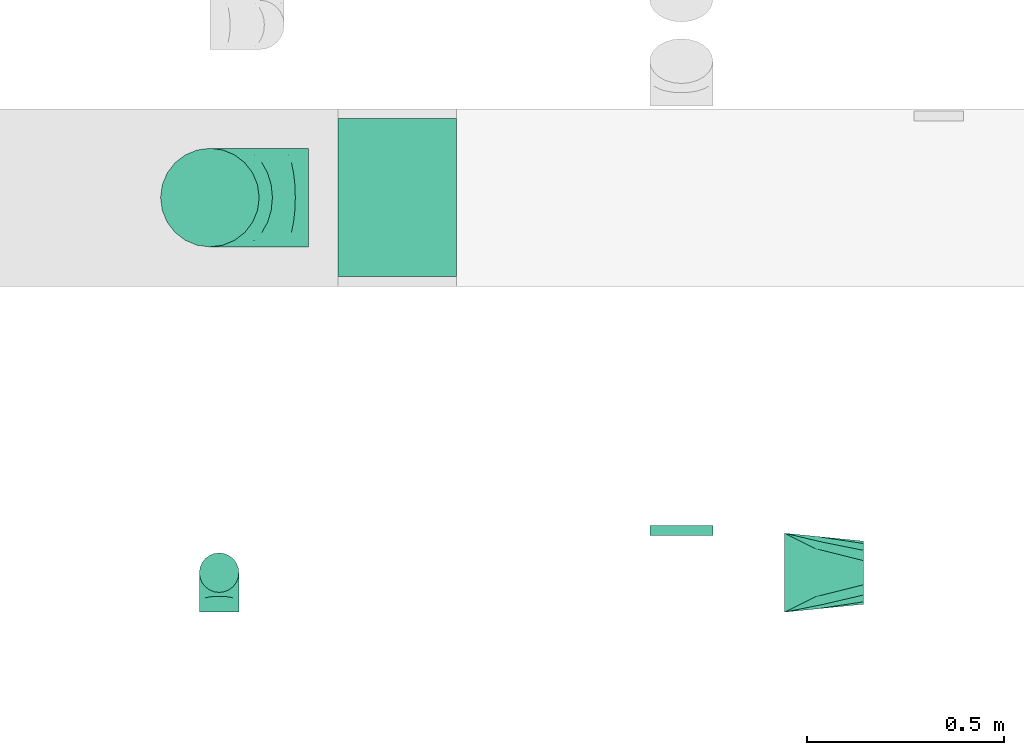
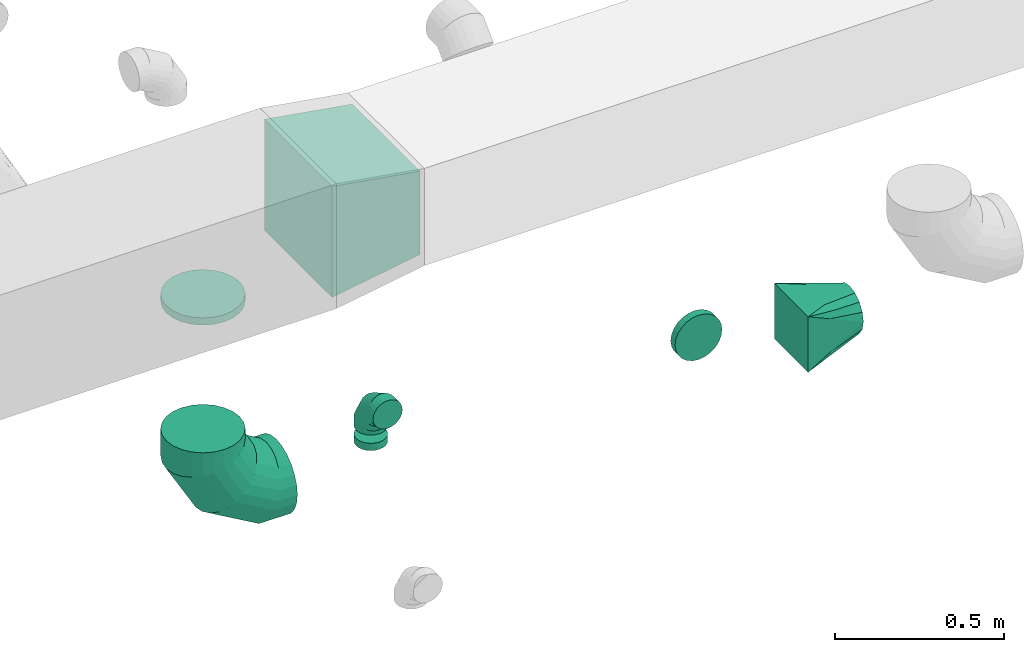
# One storey, part 68 of 97: 7 flow fittings.
"""IFC2X3 building model written with IfcOpenShell, lengths in millimetres."""

from ifc_helpers import new_model, entity, si_unit, converted_unit, derived_unit, direction, frame, origin, place, context, subcontext, project, spatial, polyline, outline, extrude, faceted_brep, source, transform, mapped, material, type_object, type_shapes, element, save


model = new_model("IFC2X3")

# Units and contexts
model_context = context("Model", 3, precision=0.01, world=origin(), true_north=direction((6.12303176911189e-17, 1.0)))
body_context = subcontext(model_context, "Body", "Model", "MODEL_VIEW")
ifc_project = project(units=[si_unit("LENGTHUNIT", "METRE", prefix="MILLI"), si_unit("AREAUNIT", "SQUARE_METRE"), si_unit("VOLUMEUNIT", "CUBIC_METRE"), converted_unit("PLANEANGLEUNIT", "DEGREE", entity("IfcRatioMeasure", 0.0174532925199433), si_unit("PLANEANGLEUNIT", "RADIAN"), dimensions=[0, 0, 0, 0, 0, 0, 0]), si_unit("MASSUNIT", "GRAM", prefix="KILO"), derived_unit("MASSDENSITYUNIT", [(si_unit("MASSUNIT", "GRAM", prefix="KILO"), 1), (si_unit("LENGTHUNIT", "METRE"), -3)]), derived_unit("MOMENTOFINERTIAUNIT", [(si_unit("LENGTHUNIT", "METRE"), 4)]), si_unit("TIMEUNIT", "SECOND"), si_unit("FREQUENCYUNIT", "HERTZ"), si_unit("THERMODYNAMICTEMPERATUREUNIT", "DEGREE_CELSIUS"), derived_unit("THERMALTRANSMITTANCEUNIT", [(si_unit("MASSUNIT", "GRAM", prefix="KILO"), 1), (si_unit("THERMODYNAMICTEMPERATUREUNIT", "KELVIN"), -1), (si_unit("TIMEUNIT", "SECOND"), -3)]), derived_unit("VOLUMETRICFLOWRATEUNIT", [(si_unit("LENGTHUNIT", "METRE"), 3), (si_unit("TIMEUNIT", "SECOND"), -1)]), derived_unit("MASSFLOWRATEUNIT", [(si_unit("MASSUNIT", "GRAM", prefix="KILO"), 1), (si_unit("TIMEUNIT", "SECOND"), -1)]), derived_unit("ROTATIONALFREQUENCYUNIT", [(si_unit("TIMEUNIT", "SECOND"), -1)]), si_unit("ELECTRICCURRENTUNIT", "AMPERE"), si_unit("ELECTRICVOLTAGEUNIT", "VOLT"), si_unit("POWERUNIT", "WATT"), si_unit("FORCEUNIT", "NEWTON", prefix="KILO"), si_unit("ILLUMINANCEUNIT", "LUX"), si_unit("LUMINOUSFLUXUNIT", "LUMEN"), si_unit("LUMINOUSINTENSITYUNIT", "CANDELA"), derived_unit("USERDEFINED", [(si_unit("MASSUNIT", "GRAM", prefix="KILO"), -1), (si_unit("LENGTHUNIT", "METRE"), -2), (si_unit("TIMEUNIT", "SECOND"), 3), (si_unit("LUMINOUSFLUXUNIT", "LUMEN"), 1)]), derived_unit("LINEARVELOCITYUNIT", [(si_unit("LENGTHUNIT", "METRE"), 1), (si_unit("TIMEUNIT", "SECOND"), -1)]), si_unit("PRESSUREUNIT", "PASCAL"), derived_unit("USERDEFINED", [(si_unit("LENGTHUNIT", "METRE"), -2), (si_unit("MASSUNIT", "GRAM", prefix="KILO"), 1), (si_unit("TIMEUNIT", "SECOND"), -2)]), derived_unit("LINEARFORCEUNIT", [(si_unit("MASSUNIT", "GRAM", prefix="KILO"), 1), (si_unit("LENGTHUNIT", "METRE"), 1), (si_unit("TIMEUNIT", "SECOND"), -2), (si_unit("LENGTHUNIT", "METRE"), -1)]), derived_unit("PLANARFORCEUNIT", [(si_unit("MASSUNIT", "GRAM", prefix="KILO"), 1), (si_unit("LENGTHUNIT", "METRE"), 1), (si_unit("TIMEUNIT", "SECOND"), -2), (si_unit("LENGTHUNIT", "METRE"), -2)])], contexts=[model_context])

# Site, building, storey
site_placement = place(None, origin())
site = spatial("IfcSite", under=ifc_project, at=site_placement, CompositionType="ELEMENT")
building_placement = place(site_placement, origin())
building = spatial("IfcBuilding", under=site, at=building_placement, CompositionType="ELEMENT")
storey_placement = place(building_placement, frame((0.0, 0.0, -4900.0)))
storey = spatial("IfcBuildingStorey", under=building, at=storey_placement, CompositionType="ELEMENT", Elevation=-4900.0)

# Flow fittings
ifc_material = material()
duct_fitting_type_1 = type_object("IfcDuctFittingType", PredefinedType="NOTDEFINED", material=ifc_material)
shared_shape_1 = source(origin(), body_context, "Body", "SweptSolid", [
    extrude(outline(polyline([(-180.84, -172.62), (123.3, -172.62), (172.62, 123.3), (-115.08, 221.94), (-180.84, -172.62)])), frame((150.0, -200.0, 0.0), z_axis=(0.0, 1.0, 0.0), x_axis=(0.986393923832128, 0.0, -0.16439898730545)), (0.0, 0.0, 1.0), 400.0),
])
type_shapes(duct_fitting_type_1, [shared_shape_1])
flow_fitting_1_placement = place(storey_placement, frame((55315.5, 15348.96, 4050.0)))
element("IfcFlowFitting", 1, at=flow_fitting_1_placement, inside=storey, type_object=duct_fitting_type_1, material=ifc_material, context=body_context, shape_type="MappedRepresentation", body=[
    mapped(shared_shape_1, transform((0.0, 0.0, 0.0), scale=1.0)),
])
duct_fitting_type_2 = type_object("IfcDuctFittingType", PredefinedType="NOTDEFINED", material=ifc_material)
shared_shape_2 = source(origin(), body_context, "Body", "Brep", [
    faceted_brep([(-100.0, 0.0, -50.0), (-100.0, -12.94, -48.3), (-100.0, -25.0, -43.3), (-100.0, -35.36, -35.36), (-100.0, -43.3, -25.0), (-100.0, -48.3, -12.94), (-100.0, -50.0, 0.0), (-100.0, -48.3, 12.94), (-100.0, -43.3, 25.0), (-100.0, -35.36, 35.36), (-100.0, -25.0, 43.3), (-100.0, -12.94, 48.3), (-100.0, 0.0, 50.0), (-100.0, 12.94, 48.3), (-100.0, 25.0, 43.3), (-100.0, 35.36, 35.36), (-100.0, 43.3, 25.0), (-100.0, 48.3, 12.94), (-100.0, 50.0, 0.0), (-100.0, 48.3, -12.94), (-100.0, 43.3, -25.0), (-100.0, 35.36, -35.36), (-100.0, 25.0, -43.3), (-100.0, 12.94, -48.3), (-76.67, 12.94, 48.3), (-79.9, 25.0, 43.3), (-73.21, 0.0, 50.0), (-82.68, 35.36, 35.36), (-86.15, 48.3, 12.94), (-86.6, 50.0, 0.0), (-84.81, 43.3, 25.0), (-84.81, 43.3, -25.0), (-82.68, 35.36, -35.36), (-86.15, 48.3, -12.94), (-76.67, 12.94, -48.3), (-73.21, 0.0, -50.0), (-79.9, 25.0, -43.3), (-69.74, -12.94, -48.3), (-66.51, -25.0, -43.3), (-63.73, -35.36, -35.36), (-61.6, -43.3, -25.0), (-60.26, -48.3, -12.94), (-59.81, -50.0, 0.0), (-60.26, -48.3, 12.94), (-61.6, -43.3, 25.0), (-63.73, -35.36, 35.36), (-66.51, -25.0, 43.3), (-69.74, -12.94, 48.3), (-36.27, 36.27, 48.3), (-45.1, 45.1, 43.3), (-26.79, 26.79, 50.0), (-52.68, 52.68, 35.36), (-58.49, 58.49, 25.0), (-62.15, 62.15, 12.94), (-63.4, 63.4, 0.0), (-62.15, 62.15, -12.94), (-58.49, 58.49, -25.0), (-52.68, 52.68, -35.36), (-36.27, 36.27, -48.3), (-26.79, 26.79, -50.0), (-45.1, 45.1, -43.3), (-17.32, 17.32, -48.3), (-8.49, 8.49, -43.3), (-0.91, 0.91, -35.36), (4.9, -4.9, -25.0), (8.56, -8.56, -12.94), (9.81, -9.81, 0.0), (8.56, -8.56, 12.94), (4.9, -4.9, 25.0), (-0.91, 0.91, 35.36), (-8.49, 8.49, 43.3), (-17.32, 17.32, 48.3), (-12.94, 76.67, 48.3), (-25.0, 79.9, 43.3), (0.0, 73.21, 50.0), (-35.36, 82.68, 35.36), (-43.3, 84.81, 25.0), (-48.3, 86.15, 12.94), (-50.0, 86.6, 0.0), (-48.3, 86.15, -12.94), (-43.3, 84.81, -25.0), (-35.36, 82.68, -35.36), (-12.94, 76.67, -48.3), (0.0, 73.21, -50.0), (-25.0, 79.9, -43.3), (12.94, 69.74, -48.3), (25.0, 66.51, -43.3), (35.36, 63.73, -35.36), (43.3, 61.6, -25.0), (48.3, 60.26, -12.94), (50.0, 59.81, 0.0), (48.3, 60.26, 12.94), (43.3, 61.6, 25.0), (35.36, 63.73, 35.36), (25.0, 66.51, 43.3), (12.94, 69.74, 48.3), (-12.94, 100.0, -48.3), (-25.0, 100.0, -43.3), (-35.36, 100.0, -35.36), (-43.3, 100.0, -25.0), (-48.3, 100.0, -12.94), (-50.0, 100.0, 0.0), (-48.3, 100.0, 12.94), (-43.3, 100.0, 25.0), (-35.36, 100.0, 35.36), (-25.0, 100.0, 43.3), (-12.94, 100.0, 48.3), (0.0, 100.0, 50.0), (12.94, 100.0, 48.3), (25.0, 100.0, 43.3), (35.36, 100.0, 35.36), (43.3, 100.0, 25.0), (48.3, 100.0, 12.94), (50.0, 100.0, 0.0), (48.3, 100.0, -12.94), (43.3, 100.0, -25.0), (35.36, 100.0, -35.36), (25.0, 100.0, -43.3), (12.94, 100.0, -48.3), (0.0, 100.0, -50.0)], [[[0, 1, 2, 3, 4, 5, 6, 7, 8, 9, 10, 11, 12, 13, 14, 15, 16, 17, 18, 19, 20, 21, 22, 23]], [[24, 25, 14, 13]], [[26, 24, 13, 12]], [[14, 25, 27, 15]], [[28, 29, 18, 17]], [[30, 28, 17, 16]], [[15, 27, 30, 16]], [[20, 31, 32, 21]], [[33, 31, 20, 19]], [[18, 29, 33, 19]], [[34, 35, 0, 23]], [[36, 34, 23, 22]], [[32, 36, 22, 21]], [[2, 1, 37, 38]], [[3, 2, 38, 39]], [[0, 35, 37, 1]], [[5, 4, 40, 41]], [[6, 5, 41, 42]], [[3, 39, 40, 4]], [[6, 42, 43, 7]], [[7, 43, 44, 8]], [[8, 44, 45, 9]], [[10, 46, 47, 11]], [[11, 47, 26, 12]], [[10, 9, 45, 46]], [[48, 49, 25, 24]], [[50, 48, 24, 26]], [[27, 25, 49, 51]], [[52, 53, 28, 30]], [[51, 52, 30, 27]], [[29, 28, 53, 54]], [[55, 56, 31, 33]], [[54, 55, 33, 29]], [[57, 32, 31, 56]], [[58, 59, 35, 34]], [[60, 58, 34, 36]], [[57, 60, 36, 32]], [[37, 35, 59, 61]], [[38, 37, 61, 62]], [[39, 38, 62, 63]], [[41, 40, 64, 65]], [[42, 41, 65, 66]], [[63, 64, 40, 39]], [[43, 42, 66, 67]], [[44, 43, 67, 68]], [[68, 69, 45, 44]], [[46, 45, 69, 70]], [[47, 46, 70, 71]], [[26, 47, 71, 50]], [[72, 73, 49, 48]], [[74, 72, 48, 50]], [[51, 49, 73, 75]], [[76, 77, 53, 52]], [[75, 76, 52, 51]], [[54, 53, 77, 78]], [[79, 80, 56, 55]], [[78, 79, 55, 54]], [[81, 57, 56, 80]], [[82, 83, 59, 58]], [[84, 82, 58, 60]], [[81, 84, 60, 57]], [[61, 59, 83, 85]], [[62, 61, 85, 86]], [[63, 62, 86, 87]], [[65, 64, 88, 89]], [[66, 65, 89, 90]], [[87, 88, 64, 63]], [[67, 66, 90, 91]], [[68, 67, 91, 92]], [[92, 93, 69, 68]], [[70, 69, 93, 94]], [[71, 70, 94, 95]], [[50, 71, 95, 74]], [[96, 97, 98, 99, 100, 101, 102, 103, 104, 105, 106, 107, 108, 109, 110, 111, 112, 113, 114, 115, 116, 117, 118, 119]], [[72, 74, 107, 106]], [[73, 72, 106, 105]], [[75, 73, 105, 104]], [[77, 76, 103, 102]], [[78, 77, 102, 101]], [[75, 104, 103, 76]], [[78, 101, 100, 79]], [[79, 100, 99, 80]], [[80, 99, 98, 81]], [[96, 119, 83, 82]], [[97, 96, 82, 84]], [[84, 81, 98, 97]], [[83, 119, 118, 85]], [[85, 118, 117, 86]], [[86, 117, 116, 87]], [[88, 115, 114, 89]], [[89, 114, 113, 90]], [[87, 116, 115, 88]], [[91, 90, 113, 112]], [[92, 91, 112, 111]], [[93, 92, 111, 110]], [[95, 94, 109, 108]], [[74, 95, 108, 107]], [[110, 109, 94, 93]]]),
])
type_shapes(duct_fitting_type_2, [shared_shape_2])
flow_fitting_2_placement = place(storey_placement, frame((55014.22, 14398.39, 4050.0), z_axis=(1.0, 0.0, 0.0), x_axis=(0.0, 0.0, 1.0)))
element("IfcFlowFitting", 2, at=flow_fitting_2_placement, inside=storey, type_object=duct_fitting_type_2, material=ifc_material, context=body_context, shape_type="MappedRepresentation", body=[
    mapped(shared_shape_2, transform((0.0, 0.0, 0.0), scale=1.0)),
])
duct_fitting_type_3 = type_object("IfcDuctFittingType", PredefinedType="NOTDEFINED", material=ifc_material)
shared_shape_3 = source(origin(), body_context, "Body", "Brep", [
    faceted_brep([(-250.0, 0.0, -125.0), (-250.0, -32.35, -120.74), (-250.0, -62.5, -108.25), (-250.0, -88.39, -88.39), (-250.0, -108.25, -62.5), (-250.0, -120.74, -32.35), (-250.0, -125.0, 0.0), (-250.0, -120.74, 32.35), (-250.0, -108.25, 62.5), (-250.0, -88.39, 88.39), (-250.0, -62.5, 108.25), (-250.0, -32.35, 120.74), (-250.0, 0.0, 125.0), (-250.0, 32.35, 120.74), (-250.0, 62.5, 108.25), (-250.0, 88.39, 88.39), (-250.0, 108.25, 62.5), (-250.0, 120.74, 32.35), (-250.0, 125.0, 0.0), (-250.0, 120.74, -32.35), (-250.0, 108.25, -62.5), (-250.0, 88.39, -88.39), (-250.0, 62.5, -108.25), (-250.0, 32.35, -120.74), (-191.68, 32.35, 120.74), (-199.76, 62.5, 108.25), (-183.01, 0.0, 125.0), (-206.7, 88.39, 88.39), (-215.37, 120.74, 32.35), (-216.51, 125.0, 0.0), (-212.02, 108.25, 62.5), (-212.02, 108.25, -62.5), (-206.7, 88.39, -88.39), (-215.37, 120.74, -32.35), (-191.68, 32.35, -120.74), (-183.01, 0.0, -125.0), (-199.76, 62.5, -108.25), (-174.34, -32.35, -120.74), (-166.27, -62.5, -108.25), (-159.33, -88.39, -88.39), (-154.01, -108.25, -62.5), (-150.66, -120.74, -32.35), (-149.52, -125.0, 0.0), (-150.66, -120.74, 32.35), (-154.01, -108.25, 62.5), (-159.33, -88.39, 88.39), (-166.27, -62.5, 108.25), (-174.34, -32.35, 120.74), (-90.67, 90.67, 120.74), (-112.74, 112.74, 108.25), (-66.99, 66.99, 125.0), (-131.69, 131.69, 88.39), (-146.23, 146.23, 62.5), (-155.38, 155.38, 32.35), (-158.49, 158.49, 0.0), (-155.38, 155.38, -32.35), (-146.23, 146.23, -62.5), (-131.69, 131.69, -88.39), (-90.67, 90.67, -120.74), (-66.99, 66.99, -125.0), (-112.74, 112.74, -108.25), (-43.3, 43.3, -120.74), (-21.23, 21.23, -108.25), (-2.28, 2.28, -88.39), (12.26, -12.26, -62.5), (21.4, -21.4, -32.35), (24.52, -24.52, 0.0), (21.4, -21.4, 32.35), (12.26, -12.26, 62.5), (-2.28, 2.28, 88.39), (-21.23, 21.23, 108.25), (-43.3, 43.3, 120.74), (-32.35, 191.68, 120.74), (-62.5, 199.76, 108.25), (0.0, 183.01, 125.0), (-88.39, 206.7, 88.39), (-108.25, 212.02, 62.5), (-120.74, 215.37, 32.35), (-125.0, 216.51, 0.0), (-120.74, 215.37, -32.35), (-108.25, 212.02, -62.5), (-88.39, 206.7, -88.39), (-32.35, 191.68, -120.74), (0.0, 183.01, -125.0), (-62.5, 199.76, -108.25), (32.35, 174.34, -120.74), (62.5, 166.27, -108.25), (88.39, 159.33, -88.39), (108.25, 154.01, -62.5), (120.74, 150.66, -32.35), (125.0, 149.52, 0.0), (120.74, 150.66, 32.35), (108.25, 154.01, 62.5), (88.39, 159.33, 88.39), (62.5, 166.27, 108.25), (32.35, 174.34, 120.74), (-32.35, 250.0, -120.74), (-62.5, 250.0, -108.25), (-88.39, 250.0, -88.39), (-108.25, 250.0, -62.5), (-120.74, 250.0, -32.35), (-125.0, 250.0, 0.0), (-120.74, 250.0, 32.35), (-108.25, 250.0, 62.5), (-88.39, 250.0, 88.39), (-62.5, 250.0, 108.25), (-32.35, 250.0, 120.74), (0.0, 250.0, 125.0), (32.35, 250.0, 120.74), (62.5, 250.0, 108.25), (88.39, 250.0, 88.39), (108.25, 250.0, 62.5), (120.74, 250.0, 32.35), (125.0, 250.0, 0.0), (120.74, 250.0, -32.35), (108.25, 250.0, -62.5), (88.39, 250.0, -88.39), (62.5, 250.0, -108.25), (32.35, 250.0, -120.74), (0.0, 250.0, -125.0)], [[[0, 1, 2, 3, 4, 5, 6, 7, 8, 9, 10, 11, 12, 13, 14, 15, 16, 17, 18, 19, 20, 21, 22, 23]], [[24, 25, 14, 13]], [[26, 24, 13, 12]], [[14, 25, 27, 15]], [[28, 29, 18, 17]], [[30, 28, 17, 16]], [[15, 27, 30, 16]], [[20, 31, 32, 21]], [[33, 31, 20, 19]], [[18, 29, 33, 19]], [[34, 35, 0, 23]], [[36, 34, 23, 22]], [[21, 32, 36, 22]], [[1, 0, 35, 37]], [[2, 1, 37, 38]], [[38, 39, 3, 2]], [[5, 4, 40, 41]], [[6, 5, 41, 42]], [[39, 40, 4, 3]], [[6, 42, 43, 7]], [[7, 43, 44, 8]], [[8, 44, 45, 9]], [[9, 45, 46, 10]], [[10, 46, 47, 11]], [[26, 12, 11, 47]], [[48, 49, 25, 24]], [[50, 48, 24, 26]], [[27, 25, 49, 51]], [[52, 53, 28, 30]], [[51, 52, 30, 27]], [[29, 28, 53, 54]], [[55, 56, 31, 33]], [[54, 55, 33, 29]], [[32, 31, 56, 57]], [[58, 59, 35, 34]], [[60, 58, 34, 36]], [[57, 60, 36, 32]], [[37, 35, 59, 61]], [[38, 37, 61, 62]], [[39, 38, 62, 63]], [[41, 40, 64, 65]], [[42, 41, 65, 66]], [[63, 64, 40, 39]], [[43, 42, 66, 67]], [[44, 43, 67, 68]], [[68, 69, 45, 44]], [[46, 45, 69, 70]], [[47, 46, 70, 71]], [[26, 47, 71, 50]], [[72, 73, 49, 48]], [[74, 72, 48, 50]], [[51, 49, 73, 75]], [[76, 77, 53, 52]], [[75, 76, 52, 51]], [[54, 53, 77, 78]], [[79, 80, 56, 55]], [[78, 79, 55, 54]], [[57, 56, 80, 81]], [[82, 83, 59, 58]], [[84, 82, 58, 60]], [[81, 84, 60, 57]], [[61, 59, 83, 85]], [[62, 61, 85, 86]], [[63, 62, 86, 87]], [[65, 64, 88, 89]], [[66, 65, 89, 90]], [[87, 88, 64, 63]], [[67, 66, 90, 91]], [[68, 67, 91, 92]], [[92, 93, 69, 68]], [[70, 69, 93, 94]], [[71, 70, 94, 95]], [[50, 71, 95, 74]], [[96, 97, 98, 99, 100, 101, 102, 103, 104, 105, 106, 107, 108, 109, 110, 111, 112, 113, 114, 115, 116, 117, 118, 119]], [[72, 74, 107, 106]], [[73, 72, 106, 105]], [[75, 73, 105, 104]], [[77, 76, 103, 102]], [[78, 77, 102, 101]], [[75, 104, 103, 76]], [[78, 101, 100, 79]], [[79, 100, 99, 80]], [[80, 99, 98, 81]], [[84, 97, 96, 82]], [[82, 96, 119, 83]], [[84, 81, 98, 97]], [[83, 119, 118, 85]], [[85, 118, 117, 86]], [[116, 87, 86, 117]], [[88, 115, 114, 89]], [[89, 114, 113, 90]], [[115, 88, 87, 116]], [[91, 90, 113, 112]], [[92, 91, 112, 111]], [[111, 110, 93, 92]], [[95, 94, 109, 108]], [[74, 95, 108, 107]], [[110, 109, 94, 93]]]),
])
type_shapes(duct_fitting_type_3, [shared_shape_3])
flow_fitting_3_placement = place(storey_placement, frame((54990.79, 15348.96, 3120.0), z_axis=(0.0, 1.0, 0.0), x_axis=(-1.0, 0.0, 0.0)))
element("IfcFlowFitting", 3, at=flow_fitting_3_placement, inside=storey, type_object=duct_fitting_type_3, material=ifc_material, context=body_context, shape_type="MappedRepresentation", body=[
    mapped(shared_shape_3, transform((0.0, 0.0, 0.0), scale=1.0)),
])
duct_fitting_type_4 = type_object("IfcDuctFittingType", PredefinedType="NOTDEFINED", material=ifc_material)
shared_shape_4 = source(origin(), body_context, "Body", "Brep", [
    faceted_brep([(20.0, 0.0, -125.0), (20.0, 32.35, -120.74), (20.0, 62.5, -108.25), (20.0, 88.39, -88.39), (20.0, 108.25, -62.5), (20.0, 120.74, -32.35), (20.0, 125.0, 0.0), (20.0, 120.74, 32.35), (20.0, 108.25, 62.5), (20.0, 88.39, 88.39), (20.0, 62.5, 108.25), (20.0, 32.35, 120.74), (20.0, 0.0, 125.0), (20.0, -32.35, 120.74), (20.0, -62.5, 108.25), (20.0, -88.39, 88.39), (20.0, -108.25, 62.5), (20.0, -120.74, 32.35), (20.0, -125.0, 0.0), (20.0, -120.74, -32.35), (20.0, -108.25, -62.5), (20.0, -88.39, -88.39), (20.0, -62.5, -108.25), (20.0, -32.35, -120.74), (0.0, 0.0, 125.0), (-6.1, 0.0, 125.0), (-6.1, -32.35, 120.74), (0.0, -32.35, 120.74), (-6.1, -62.5, 108.25), (0.0, -62.5, 108.25), (0.0, -88.39, 88.39), (-6.1, -88.39, 88.39), (0.0, -108.25, 62.5), (-6.1, -108.25, 62.5), (-6.1, -120.74, 32.35), (0.0, -120.74, 32.35), (-6.1, -125.0, 0.0), (0.0, -125.0, 0.0), (-6.1, -120.74, -32.35), (0.0, -120.74, -32.35), (-6.1, -108.25, -62.5), (0.0, -108.25, -62.5), (0.0, -88.39, -88.39), (-6.1, -88.39, -88.39), (0.0, -62.5, -108.25), (-6.1, -62.5, -108.25), (-6.1, -32.35, -120.74), (0.0, -32.35, -120.74), (-6.1, 0.0, -125.0), (0.0, 0.0, -125.0), (-6.1, 32.35, -120.74), (0.0, 32.35, -120.74), (-6.1, 62.5, -108.25), (0.0, 62.5, -108.25), (0.0, 88.39, -88.39), (-6.1, 88.39, -88.39), (0.0, 108.25, -62.5), (-6.1, 108.25, -62.5), (-6.1, 120.74, -32.35), (0.0, 120.74, -32.35), (-6.1, 125.0, 0.0), (0.0, 125.0, 0.0), (-6.1, 120.74, 32.35), (0.0, 120.74, 32.35), (-6.1, 108.25, 62.5), (0.0, 108.25, 62.5), (0.0, 88.39, 88.39), (-6.1, 88.39, 88.39), (0.0, 62.5, 108.25), (-6.1, 62.5, 108.25), (-6.1, 32.35, 120.74), (0.0, 32.35, 120.74)], [[[0, 1, 2, 3, 4, 5, 6, 7, 8, 9, 10, 11, 12, 13, 14, 15, 16, 17, 18, 19, 20, 21, 22, 23]], [[13, 12, 24, 25, 26, 27]], [[14, 13, 27, 26, 28, 29]], [[30, 15, 14, 29, 28, 31]], [[17, 16, 32, 33, 34, 35]], [[18, 17, 35, 34, 36, 37]], [[32, 16, 15, 30, 31, 33]], [[19, 18, 37, 36, 38, 39]], [[20, 19, 39, 38, 40, 41]], [[42, 21, 20, 41, 40, 43]], [[23, 22, 44, 45, 46, 47]], [[0, 23, 47, 46, 48, 49]], [[44, 22, 21, 42, 43, 45]], [[1, 0, 49, 48, 50, 51]], [[2, 1, 51, 50, 52, 53]], [[54, 3, 2, 53, 52, 55]], [[5, 4, 56, 57, 58, 59]], [[6, 5, 59, 58, 60, 61]], [[56, 4, 3, 54, 55, 57]], [[7, 6, 61, 60, 62, 63]], [[8, 7, 63, 62, 64, 65]], [[66, 9, 8, 65, 64, 67]], [[11, 10, 68, 69, 70, 71]], [[12, 11, 71, 70, 25, 24]], [[68, 10, 9, 66, 67, 69]], [[46, 45, 43, 40, 38, 36, 34, 33, 31, 28, 26, 25, 70, 69, 67, 64, 62, 60, 58, 57, 55, 52, 50, 48]]]),
])
type_shapes(duct_fitting_type_4, [shared_shape_4])
flow_fitting_4_placement = place(storey_placement, frame((54990.79, 15348.96, 3850.0), z_axis=(0.0, -1.0, 0.0), x_axis=(0.0, 0.0, -1.0)))
element("IfcFlowFitting", 4, at=flow_fitting_4_placement, inside=storey, type_object=duct_fitting_type_4, material=ifc_material, context=body_context, shape_type="MappedRepresentation", body=[
    mapped(shared_shape_4, transform((0.0, 0.0, 0.0), scale=1.0)),
])
duct_fitting_type_5 = type_object("IfcDuctFittingType", PredefinedType="NOTDEFINED", material=ifc_material)
shared_shape_5 = source(origin(), body_context, "Body", "Brep", [
    faceted_brep([(20.0, 20.71, -77.27), (20.0, 40.0, -69.28), (20.0, 56.57, -56.57), (20.0, 69.28, -40.0), (20.0, 77.27, -20.71), (20.0, 80.0, 0.0), (20.0, 77.27, 20.71), (20.0, 69.28, 40.0), (20.0, 56.57, 56.57), (20.0, 40.0, 69.28), (20.0, 20.71, 77.27), (20.0, 0.0, 80.0), (20.0, -20.71, 77.27), (20.0, -40.0, 69.28), (20.0, -56.57, 56.57), (20.0, -69.28, 40.0), (20.0, -77.27, 20.71), (20.0, -80.0, 0.0), (20.0, -77.27, -20.71), (20.0, -69.28, -40.0), (20.0, -56.57, -56.57), (20.0, -40.0, -69.28), (20.0, -20.71, -77.27), (20.0, 0.0, -80.0), (0.0, 0.0, 80.0), (0.0, 20.71, 77.27), (-6.1, 20.71, 77.27), (-6.1, 0.0, 80.0), (0.0, 40.0, 69.28), (-6.1, 40.0, 69.28), (0.0, 56.57, 56.57), (-6.1, 56.57, 56.57), (0.0, 69.28, 40.0), (0.0, 77.27, 20.71), (-6.1, 77.27, 20.71), (-6.1, 69.28, 40.0), (0.0, 80.0, 0.0), (-6.1, 80.0, 0.0), (0.0, 77.27, -20.71), (-6.1, 77.27, -20.71), (0.0, 69.28, -40.0), (-6.1, 69.28, -40.0), (0.0, 56.57, -56.57), (-6.1, 56.57, -56.57), (0.0, 40.0, -69.28), (0.0, 20.71, -77.27), (-6.1, 20.71, -77.27), (-6.1, 40.0, -69.28), (0.0, 0.0, -80.0), (-6.1, 0.0, -80.0), (0.0, -20.71, -77.27), (-6.1, -20.71, -77.27), (0.0, -40.0, -69.28), (-6.1, -40.0, -69.28), (0.0, -56.57, -56.57), (-6.1, -56.57, -56.57), (0.0, -69.28, -40.0), (0.0, -77.27, -20.71), (-6.1, -77.27, -20.71), (-6.1, -69.28, -40.0), (0.0, -80.0, 0.0), (-6.1, -80.0, 0.0), (0.0, -77.27, 20.71), (-6.1, -77.27, 20.71), (0.0, -69.28, 40.0), (-6.1, -69.28, 40.0), (0.0, -56.57, 56.57), (-6.1, -56.57, 56.57), (0.0, -40.0, 69.28), (0.0, -20.71, 77.27), (-6.1, -20.71, 77.27), (-6.1, -40.0, 69.28)], [[[0, 1, 2, 3, 4, 5, 6, 7, 8, 9, 10, 11, 12, 13, 14, 15, 16, 17, 18, 19, 20, 21, 22, 23]], [[24, 11, 10, 25, 26, 27]], [[25, 10, 9, 28, 29, 26]], [[28, 9, 8, 30, 31, 29]], [[32, 7, 6, 33, 34, 35]], [[33, 6, 5, 36, 37, 34]], [[30, 8, 7, 32, 35, 31]], [[36, 5, 4, 38, 39, 37]], [[38, 4, 3, 40, 41, 39]], [[40, 3, 2, 42, 43, 41]], [[44, 1, 0, 45, 46, 47]], [[45, 0, 23, 48, 49, 46]], [[42, 2, 1, 44, 47, 43]], [[48, 23, 22, 50, 51, 49]], [[50, 22, 21, 52, 53, 51]], [[52, 21, 20, 54, 55, 53]], [[56, 19, 18, 57, 58, 59]], [[57, 18, 17, 60, 61, 58]], [[54, 20, 19, 56, 59, 55]], [[60, 17, 16, 62, 63, 61]], [[62, 16, 15, 64, 65, 63]], [[64, 15, 14, 66, 67, 65]], [[68, 13, 12, 69, 70, 71]], [[69, 12, 11, 24, 27, 70]], [[66, 14, 13, 68, 71, 67]], [[49, 51, 53, 55, 59, 58, 61, 63, 65, 67, 71, 70, 27, 26, 29, 31, 35, 34, 37, 39, 41, 43, 47, 46]]]),
])
type_shapes(duct_fitting_type_5, [shared_shape_5])
flow_fitting_5_placement = place(storey_placement, frame((56185.54, 14498.39, 3800.0), z_axis=(0.0, 0.0, -1.0), x_axis=(0.0, 1.0, 0.0)))
element("IfcFlowFitting", 5, at=flow_fitting_5_placement, inside=storey, type_object=duct_fitting_type_5, material=ifc_material, context=body_context, shape_type="MappedRepresentation", body=[
    mapped(shared_shape_5, transform((0.0, 0.0, 0.0), scale=1.0)),
])
duct_fitting_type_6 = type_object("IfcDuctFittingType", PredefinedType="NOTDEFINED", material=ifc_material)
shared_shape_6 = source(origin(), body_context, "Body", "Brep", [
    faceted_brep([(20.0, 12.94, -48.3), (20.0, 25.0, -43.3), (20.0, 35.36, -35.36), (20.0, 43.3, -25.0), (20.0, 48.3, -12.94), (20.0, 50.0, 0.0), (20.0, 48.3, 12.94), (20.0, 43.3, 25.0), (20.0, 35.36, 35.36), (20.0, 25.0, 43.3), (20.0, 12.94, 48.3), (20.0, 0.0, 50.0), (20.0, -12.94, 48.3), (20.0, -25.0, 43.3), (20.0, -35.36, 35.36), (20.0, -43.3, 25.0), (20.0, -48.3, 12.94), (20.0, -50.0, 0.0), (20.0, -48.3, -12.94), (20.0, -43.3, -25.0), (20.0, -35.36, -35.36), (20.0, -25.0, -43.3), (20.0, -12.94, -48.3), (20.0, 0.0, -50.0), (0.0, 0.0, 50.0), (0.0, 12.94, 48.3), (-6.1, 12.94, 48.3), (-6.1, 0.0, 50.0), (0.0, 25.0, 43.3), (-6.1, 25.0, 43.3), (0.0, 35.36, 35.36), (-6.1, 35.36, 35.36), (0.0, 43.3, 25.0), (0.0, 48.3, 12.94), (-6.1, 48.3, 12.94), (-6.1, 43.3, 25.0), (0.0, 50.0, 0.0), (-6.1, 50.0, 0.0), (0.0, 48.3, -12.94), (-6.1, 48.3, -12.94), (0.0, 43.3, -25.0), (-6.1, 43.3, -25.0), (0.0, 35.36, -35.36), (-6.1, 35.36, -35.36), (0.0, 25.0, -43.3), (0.0, 12.94, -48.3), (-6.1, 12.94, -48.3), (-6.1, 25.0, -43.3), (0.0, 0.0, -50.0), (-6.1, 0.0, -50.0), (0.0, -12.94, -48.3), (-6.1, -12.94, -48.3), (0.0, -25.0, -43.3), (-6.1, -25.0, -43.3), (0.0, -35.36, -35.36), (-6.1, -35.36, -35.36), (0.0, -43.3, -25.0), (0.0, -48.3, -12.94), (-6.1, -48.3, -12.94), (-6.1, -43.3, -25.0), (0.0, -50.0, 0.0), (-6.1, -50.0, 0.0), (0.0, -48.3, 12.94), (-6.1, -48.3, 12.94), (0.0, -43.3, 25.0), (-6.1, -43.3, 25.0), (0.0, -35.36, 35.36), (-6.1, -35.36, 35.36), (0.0, -25.0, 43.3), (0.0, -12.94, 48.3), (-6.1, -12.94, 48.3), (-6.1, -25.0, 43.3)], [[[0, 1, 2, 3, 4, 5, 6, 7, 8, 9, 10, 11, 12, 13, 14, 15, 16, 17, 18, 19, 20, 21, 22, 23]], [[24, 11, 10, 25, 26, 27]], [[25, 10, 9, 28, 29, 26]], [[28, 9, 8, 30, 31, 29]], [[32, 7, 6, 33, 34, 35]], [[33, 6, 5, 36, 37, 34]], [[30, 8, 7, 32, 35, 31]], [[36, 5, 4, 38, 39, 37]], [[38, 4, 3, 40, 41, 39]], [[40, 3, 2, 42, 43, 41]], [[44, 1, 0, 45, 46, 47]], [[45, 0, 23, 48, 49, 46]], [[42, 2, 1, 44, 47, 43]], [[48, 23, 22, 50, 51, 49]], [[50, 22, 21, 52, 53, 51]], [[52, 21, 20, 54, 55, 53]], [[56, 19, 18, 57, 58, 59]], [[57, 18, 17, 60, 61, 58]], [[54, 20, 19, 56, 59, 55]], [[60, 17, 16, 62, 63, 61]], [[62, 16, 15, 64, 65, 63]], [[64, 15, 14, 66, 67, 65]], [[68, 13, 12, 69, 70, 71]], [[69, 12, 11, 24, 27, 70]], [[66, 14, 13, 68, 71, 67]], [[49, 51, 53, 55, 59, 58, 61, 63, 65, 67, 71, 70, 27, 26, 29, 31, 35, 34, 37, 39, 41, 43, 47, 46]]]),
])
type_shapes(duct_fitting_type_6, [shared_shape_6])
flow_fitting_6_placement = place(storey_placement, frame((55014.22, 14398.39, 3900.0), z_axis=(0.0, 1.0, 0.0), x_axis=(0.0, 0.0, 1.0)))
element("IfcFlowFitting", 6, at=flow_fitting_6_placement, inside=storey, type_object=duct_fitting_type_6, material=ifc_material, context=body_context, shape_type="MappedRepresentation", body=[
    mapped(shared_shape_6, transform((0.0, 0.0, 0.0), scale=1.0)),
])
duct_fitting_type_7 = type_object("IfcDuctFittingType", PredefinedType="NOTDEFINED", material=ifc_material)
shared_shape_7 = source(origin(), body_context, "Body", "Brep", [
    faceted_brep([(200.0, 30.61, 73.91), (200.0, 22.87, 75.45), (200.0, 15.12, 76.99), (200.0, 11.34, 77.74), (200.0, 7.56, 78.5), (200.0, 0.0, 80.0), (200.0, -7.56, 78.5), (200.0, -15.12, 76.99), (200.0, -18.99, 76.22), (200.0, -22.87, 75.45), (200.0, -30.61, 73.91), (200.0, -37.1, 69.57), (200.0, -43.59, 65.24), (200.0, -50.08, 60.9), (200.0, -56.57, 56.57), (200.0, -60.9, 50.08), (200.0, -65.24, 43.59), (200.0, -69.57, 37.1), (200.0, -73.91, 30.61), (200.0, -75.45, 22.87), (200.0, -76.99, 15.12), (200.0, -77.74, 11.34), (200.0, -78.5, 7.56), (200.0, -80.0, 0.0), (200.0, -78.5, -7.56), (200.0, -76.99, -15.12), (200.0, -76.22, -18.99), (200.0, -75.45, -22.87), (200.0, -73.91, -30.61), (200.0, -69.57, -37.1), (200.0, -65.24, -43.59), (200.0, -60.9, -50.08), (200.0, -56.57, -56.57), (200.0, -50.08, -60.9), (200.0, -43.59, -65.24), (200.0, -37.1, -69.57), (200.0, -30.61, -73.91), (200.0, -22.87, -75.45), (200.0, -15.12, -76.99), (200.0, -11.34, -77.74), (200.0, -7.56, -78.5), (200.0, 0.0, -80.0), (200.0, 7.56, -78.5), (200.0, 15.12, -76.99), (200.0, 18.99, -76.22), (200.0, 22.87, -75.45), (200.0, 30.61, -73.91), (200.0, 37.1, -69.57), (200.0, 43.59, -65.24), (200.0, 50.08, -60.9), (200.0, 56.57, -56.57), (200.0, 60.9, -50.08), (200.0, 65.24, -43.59), (200.0, 69.57, -37.1), (200.0, 73.91, -30.61), (200.0, 75.45, -22.87), (200.0, 76.99, -15.12), (200.0, 77.74, -11.34), (200.0, 78.5, -7.56), (200.0, 80.0, 0.0), (200.0, 78.5, 7.56), (200.0, 76.99, 15.12), (200.0, 76.22, 18.99), (200.0, 75.45, 22.87), (200.0, 73.91, 30.61), (200.0, 69.57, 37.1), (200.0, 65.24, 43.59), (200.0, 60.9, 50.08), (200.0, 56.57, 56.57), (200.0, 50.08, 60.9), (200.0, 43.59, 65.24), (200.0, 37.1, 69.57), (0.0, -100.0, 100.0), (0.0, 100.0, 100.0), (0.0, 100.0, -100.0), (0.0, -100.0, -100.0), (52.06, -73.97, 94.79), (78.09, -60.96, 92.19), (176.03, -11.99, 82.4), (152.06, -23.97, 84.79), (128.09, -35.96, 87.19), (104.11, -47.94, 89.59), (100.0, -79.94, 76.52), (78.09, -92.19, 60.96), (104.11, -89.59, 47.94), (128.09, -87.19, 35.96), (152.06, -84.79, 23.97), (164.04, -83.6, 17.98), (176.03, -82.4, 11.99), (26.03, -97.4, 86.99), (52.06, -94.79, 73.97), (26.03, -86.99, 97.4), (26.03, -97.4, -86.99), (52.06, -94.79, -73.97), (78.09, -92.19, -60.96), (104.11, -89.59, -47.94), (128.09, -87.19, -35.96), (152.06, -84.79, -23.97), (176.03, -82.4, -11.99), (100.0, -76.52, -79.94), (78.09, -60.96, -92.19), (104.11, -47.94, -89.59), (128.09, -35.96, -87.19), (152.06, -23.97, -84.79), (164.04, -17.98, -83.6), (176.03, -11.99, -82.4), (26.03, -86.99, -97.4), (52.06, -73.97, -94.79), (26.03, 86.99, -97.4), (52.06, 73.97, -94.79), (78.09, 60.96, -92.19), (104.11, 47.94, -89.59), (128.09, 35.96, -87.19), (152.06, 23.97, -84.79), (176.03, 11.99, -82.4), (100.0, 79.94, -76.52), (78.09, 92.19, -60.96), (104.11, 89.59, -47.94), (128.09, 87.19, -35.96), (152.06, 84.79, -23.97), (164.04, 83.6, -17.98), (176.03, 82.4, -11.99), (26.03, 97.4, -86.99), (52.06, 94.79, -73.97), (26.03, 97.4, 86.99), (52.06, 94.79, 73.97), (78.09, 92.19, 60.96), (104.11, 89.59, 47.94), (128.09, 87.19, 35.96), (152.06, 84.79, 23.97), (176.03, 82.4, 11.99), (100.0, 76.52, 79.94), (78.09, 60.96, 92.19), (104.11, 47.94, 89.59), (128.09, 35.96, 87.19), (152.06, 23.97, 84.79), (164.04, 17.98, 83.6), (176.03, 11.99, 82.4), (26.03, 86.99, 97.4), (52.06, 73.97, 94.79)], [[[0, 1, 2, 3, 4, 5, 6, 7, 8, 9, 10, 11, 12, 13, 14, 15, 16, 17, 18, 19, 20, 21, 22, 23, 24, 25, 26, 27, 28, 29, 30, 31, 32, 33, 34, 35, 36, 37, 38, 39, 40, 41, 42, 43, 44, 45, 46, 47, 48, 49, 50, 51, 52, 53, 54, 55, 56, 57, 58, 59, 60, 61, 62, 63, 64, 65, 66, 67, 68, 69, 70, 71]], [[72, 73, 74, 75]], [[76, 12, 77]], [[12, 11, 10, 77]], [[78, 79, 80, 81, 77, 10, 9, 8, 7, 6, 5]], [[13, 82, 14]], [[20, 19, 18, 83, 84, 85, 86, 87, 88, 23, 22, 21]], [[82, 72, 89]], [[82, 15, 14]], [[83, 16, 90]], [[91, 72, 82]], [[18, 17, 16, 83]], [[90, 16, 15]], [[15, 82, 89]], [[90, 15, 89]], [[76, 13, 12]], [[13, 76, 91]], [[82, 13, 91]], [[88, 87, 86, 85, 84, 83, 90, 89, 72, 75, 92, 93, 94, 95, 96, 97, 98, 23]], [[93, 30, 94]], [[30, 29, 28, 94]], [[98, 97, 96, 95, 94, 28, 27, 26, 25, 24, 23]], [[31, 99, 32]], [[38, 37, 36, 100, 101, 102, 103, 104, 105, 41, 40, 39]], [[99, 75, 106]], [[99, 33, 32]], [[100, 34, 107]], [[92, 75, 99]], [[36, 35, 34, 100]], [[107, 34, 33]], [[33, 99, 106]], [[107, 33, 106]], [[93, 31, 30]], [[31, 93, 92]], [[99, 31, 92]], [[105, 104, 103, 102, 101, 100, 107, 106, 75, 74, 108, 109, 110, 111, 112, 113, 114, 41]], [[109, 48, 110]], [[48, 47, 46, 110]], [[114, 113, 112, 111, 110, 46, 45, 44, 43, 42, 41]], [[49, 115, 50]], [[56, 55, 54, 116, 117, 118, 119, 120, 121, 59, 58, 57]], [[115, 74, 122]], [[115, 51, 50]], [[116, 52, 123]], [[108, 74, 115]], [[54, 53, 52, 116]], [[123, 52, 51]], [[51, 115, 122]], [[123, 51, 122]], [[109, 49, 48]], [[49, 109, 108]], [[115, 49, 108]], [[74, 73, 124, 125, 126, 127, 128, 129, 130, 59, 121, 120, 119, 118, 117, 116, 123, 122]], [[125, 66, 126]], [[66, 65, 64, 126]], [[130, 129, 128, 127, 126, 64, 63, 62, 61, 60, 59]], [[67, 131, 68]], [[2, 1, 0, 132, 133, 134, 135, 136, 137, 5, 4, 3]], [[131, 73, 138]], [[131, 69, 68]], [[132, 70, 139]], [[124, 73, 131]], [[0, 71, 70, 132]], [[139, 70, 69]], [[69, 131, 138]], [[139, 69, 138]], [[125, 67, 66]], [[67, 125, 124]], [[131, 67, 124]], [[73, 72, 91, 76, 77, 81, 80, 79, 78, 5, 137, 136, 135, 134, 133, 132, 139, 138]]]),
])
type_shapes(duct_fitting_type_7, [shared_shape_7])
flow_fitting_7_placement = place(storey_placement, frame((56447.07, 14398.39, 3800.0)))
element("IfcFlowFitting", 7, at=flow_fitting_7_placement, inside=storey, type_object=duct_fitting_type_7, material=ifc_material, context=body_context, shape_type="MappedRepresentation", body=[
    mapped(shared_shape_7, transform((0.0, 0.0, 0.0), scale=1.0)),
])

save(model, "model.ifc")
